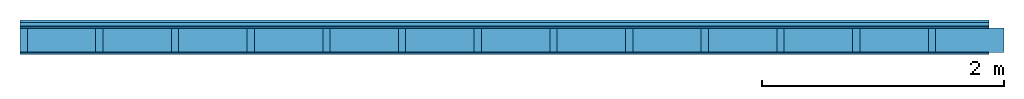
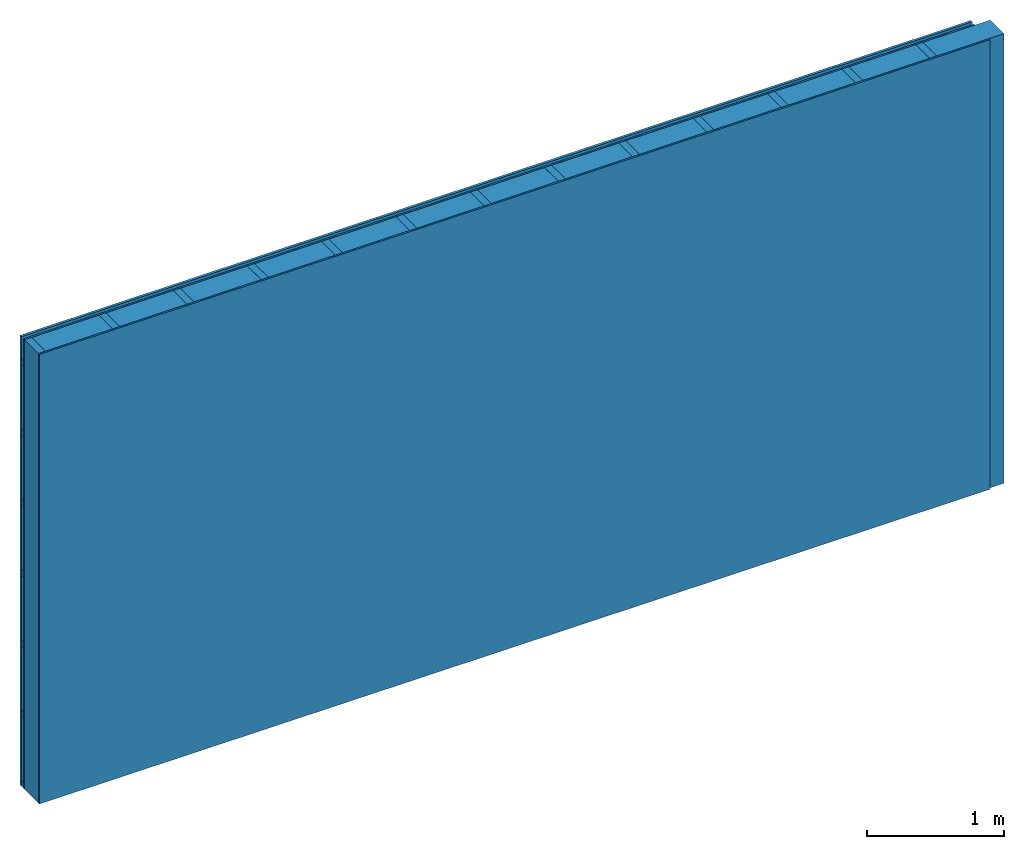
# One storey: 3 members, 3 plates, 1 element without a shape of its own.
"""IFC4 building model written with IfcOpenShell, lengths in metres."""

from ifc_helpers import new_model, si_unit, derived_unit, direction, frame, frame_2d, origin, origin_with_axes, place, context, project, spatial, rectangle, extrude, material, layer, layer_set, type_object, element, aggregate, save


model = new_model("IFC4")

# Units and contexts
plan_context = context("Plan", 3, precision=1e-05, world=origin(), true_north=direction((0.0, 1.0)))
model_context = context("Model", 3, precision=1e-05, world=origin(), true_north=direction((0.0, 1.0)))
ifc_project = project(units=[si_unit("LENGTHUNIT", "METRE"), derived_unit("SOUNDPRESSUREUNIT", [(si_unit("PRESSUREUNIT", "PASCAL", prefix="MICRO"), 0)]), si_unit("ENERGYUNIT", "JOULE", prefix="MEGA"), si_unit("MASSUNIT", "GRAM", prefix="KILO"), derived_unit("THERMALTRANSMITTANCEUNIT", [(si_unit("POWERUNIT", "WATT"), 1), (si_unit("AREAUNIT", "SQUARE_METRE"), -1), (si_unit("THERMODYNAMICTEMPERATUREUNIT", "KELVIN"), -1)]), derived_unit("AREADENSITYUNIT", [(si_unit("MASSUNIT", "GRAM", prefix="KILO"), 1), (si_unit("AREAUNIT", "SQUARE_METRE"), -1)]), derived_unit("USERDEFINED", [(si_unit("ENERGYUNIT", "JOULE", prefix="MEGA"), 1), (si_unit("AREAUNIT", "SQUARE_METRE"), -1)])], contexts=[plan_context, model_context])

# Site, building, storey
site = spatial("IfcSite", under=ifc_project)
building_placement = place(None, origin())
building = spatial("IfcBuilding", under=site, at=building_placement)
storey_placement = place(building_placement, origin())
storey = spatial("IfcBuildingStorey", under=building, at=storey_placement)

# Wall, members, plates
ifc_material_1 = material(Name="Wood cladding horizontal, closed")
ifc_layer_1 = layer(ifc_material_1, 0.022, Name="Cover 1st layer")
ifc_layer_2 = layer(None, 0.03, Name="Battens / profiles (ventilation)")
ifc_material_2 = material(Category="07.013")
ifc_layer_3 = layer(ifc_material_2, 0.015, Name="outside 1st layer")
ifc_material_3 = material(Name="of the art")
ifc_layer_4 = layer(ifc_material_3, 0.0, Name="Bond")
ifc_layer_5 = layer(None, 0.2, Name="Support")
ifc_layer_6 = layer(ifc_material_3, 0.0, Name="Bond")
ifc_material_4 = material(Category="03.007")
ifc_layer_7 = layer(ifc_material_4, 0.015, Name="1st layer")
ifc_material_5 = material(Name="Glued joints")
ifc_layer_8 = layer(ifc_material_5, 0.0, Name="Surface")
ifc_layer_set = layer_set([ifc_layer_1, ifc_layer_2, ifc_layer_3, ifc_layer_4, ifc_layer_5, ifc_layer_6, ifc_layer_7, ifc_layer_8])
wall_type = type_object("IfcWallType", Name="D0085", PredefinedType="NOTDEFINED", material=ifc_layer_set)
wall_placement = place(None, frame((0.0, 0.0, 0.0), z_axis=(0.0, -1.0, 0.0), x_axis=(1.0, 0.0, 0.0)))
wall = element("IfcWall", 1, at=wall_placement, inside=storey, type_object=wall_type, material=ifc_layer_set, Name="Wall #1")
ifc_material_6 = material()
member_1_placement = place(wall_placement, origin())
member_1 = element("IfcMember", 2, at=member_1_placement, material=ifc_material_6, Name="Battens / profiles (ventilation)", context=plan_context, shape_type="SweptSolid", body=[
    extrude(rectangle(XDim=0.05, YDim=0.03, at=frame_2d((0.025, 0.015), x_axis=(1.0, 0.0))), frame((0.0, 0.0, 0.022), z_axis=(1.0, 0.0, 0.0), x_axis=(0.0, 1.0, 0.0)), (0.0, 0.0, 1.0), 8.0),
    extrude(rectangle(XDim=0.05, YDim=0.03, at=frame_2d((0.025, 0.015), x_axis=(1.0, 0.0))), frame((0.0, 0.625, 0.022), z_axis=(1.0, 0.0, 0.0), x_axis=(0.0, 1.0, 0.0)), (0.0, 0.0, 1.0), 8.0),
    extrude(rectangle(XDim=0.05, YDim=0.03, at=frame_2d((0.025, 0.015), x_axis=(1.0, 0.0))), frame((0.0, 1.25, 0.022), z_axis=(1.0, 0.0, 0.0), x_axis=(0.0, 1.0, 0.0)), (0.0, 0.0, 1.0), 8.0),
    extrude(rectangle(XDim=0.05, YDim=0.03, at=frame_2d((0.025, 0.015), x_axis=(1.0, 0.0))), frame((0.0, 1.875, 0.022), z_axis=(1.0, 0.0, 0.0), x_axis=(0.0, 1.0, 0.0)), (0.0, 0.0, 1.0), 8.0),
    extrude(rectangle(XDim=0.05, YDim=0.03, at=frame_2d((0.025, 0.015), x_axis=(1.0, 0.0))), frame((0.0, 2.5, 0.022), z_axis=(1.0, 0.0, 0.0), x_axis=(0.0, 1.0, 0.0)), (0.0, 0.0, 1.0), 8.0),
    extrude(rectangle(XDim=0.05, YDim=0.03, at=frame_2d((0.025, 0.015), x_axis=(1.0, 0.0))), frame((0.0, 3.125, 0.022), z_axis=(1.0, 0.0, 0.0), x_axis=(0.0, 1.0, 0.0)), (0.0, 0.0, 1.0), 8.0),
    extrude(rectangle(XDim=0.05, YDim=0.03, at=frame_2d((0.025, 0.015), x_axis=(1.0, 0.0))), frame((0.0, 3.75, 0.022), z_axis=(1.0, 0.0, 0.0), x_axis=(0.0, 1.0, 0.0)), (0.0, 0.0, 1.0), 8.0),
])
ifc_material_7 = material()
member_2_placement = place(wall_placement, origin())
member_2 = element("IfcMember", 3, at=member_2_placement, material=ifc_material_7, Name="Support", context=plan_context, shape_type="SweptSolid", body=[
    extrude(rectangle(XDim=0.06, YDim=0.2, at=frame_2d((0.03, 0.1), x_axis=(1.0, 0.0))), frame((0.0, 4.0, 0.067), z_axis=(0.0, -1.0, 0.0), x_axis=(1.0, 0.0, 0.0)), (0.0, 0.0, 1.0), 4.0),
    extrude(rectangle(XDim=0.06, YDim=0.2, at=frame_2d((0.03, 0.1), x_axis=(1.0, 0.0))), frame((0.625, 4.0, 0.067), z_axis=(0.0, -1.0, 0.0), x_axis=(1.0, 0.0, 0.0)), (0.0, 0.0, 1.0), 4.0),
    extrude(rectangle(XDim=0.06, YDim=0.2, at=frame_2d((0.03, 0.1), x_axis=(1.0, 0.0))), frame((1.25, 4.0, 0.067), z_axis=(0.0, -1.0, 0.0), x_axis=(1.0, 0.0, 0.0)), (0.0, 0.0, 1.0), 4.0),
    extrude(rectangle(XDim=0.06, YDim=0.2, at=frame_2d((0.03, 0.1), x_axis=(1.0, 0.0))), frame((1.875, 4.0, 0.067), z_axis=(0.0, -1.0, 0.0), x_axis=(1.0, 0.0, 0.0)), (0.0, 0.0, 1.0), 4.0),
    extrude(rectangle(XDim=0.06, YDim=0.2, at=frame_2d((0.03, 0.1), x_axis=(1.0, 0.0))), frame((2.5, 4.0, 0.067), z_axis=(0.0, -1.0, 0.0), x_axis=(1.0, 0.0, 0.0)), (0.0, 0.0, 1.0), 4.0),
    extrude(rectangle(XDim=0.06, YDim=0.2, at=frame_2d((0.03, 0.1), x_axis=(1.0, 0.0))), frame((3.125, 4.0, 0.067), z_axis=(0.0, -1.0, 0.0), x_axis=(1.0, 0.0, 0.0)), (0.0, 0.0, 1.0), 4.0),
    extrude(rectangle(XDim=0.06, YDim=0.2, at=frame_2d((0.03, 0.1), x_axis=(1.0, 0.0))), frame((3.75, 4.0, 0.067), z_axis=(0.0, -1.0, 0.0), x_axis=(1.0, 0.0, 0.0)), (0.0, 0.0, 1.0), 4.0),
    extrude(rectangle(XDim=0.06, YDim=0.2, at=frame_2d((0.03, 0.1), x_axis=(1.0, 0.0))), frame((4.375, 4.0, 0.067), z_axis=(0.0, -1.0, 0.0), x_axis=(1.0, 0.0, 0.0)), (0.0, 0.0, 1.0), 4.0),
    extrude(rectangle(XDim=0.06, YDim=0.2, at=frame_2d((0.03, 0.1), x_axis=(1.0, 0.0))), frame((5.0, 4.0, 0.067), z_axis=(0.0, -1.0, 0.0), x_axis=(1.0, 0.0, 0.0)), (0.0, 0.0, 1.0), 4.0),
    extrude(rectangle(XDim=0.06, YDim=0.2, at=frame_2d((0.03, 0.1), x_axis=(1.0, 0.0))), frame((5.625, 4.0, 0.067), z_axis=(0.0, -1.0, 0.0), x_axis=(1.0, 0.0, 0.0)), (0.0, 0.0, 1.0), 4.0),
    extrude(rectangle(XDim=0.06, YDim=0.2, at=frame_2d((0.03, 0.1), x_axis=(1.0, 0.0))), frame((6.25, 4.0, 0.067), z_axis=(0.0, -1.0, 0.0), x_axis=(1.0, 0.0, 0.0)), (0.0, 0.0, 1.0), 4.0),
    extrude(rectangle(XDim=0.06, YDim=0.2, at=frame_2d((0.03, 0.1), x_axis=(1.0, 0.0))), frame((6.875, 4.0, 0.067), z_axis=(0.0, -1.0, 0.0), x_axis=(1.0, 0.0, 0.0)), (0.0, 0.0, 1.0), 4.0),
    extrude(rectangle(XDim=0.06, YDim=0.2, at=frame_2d((0.03, 0.1), x_axis=(1.0, 0.0))), frame((7.5, 4.0, 0.067), z_axis=(0.0, -1.0, 0.0), x_axis=(1.0, 0.0, 0.0)), (0.0, 0.0, 1.0), 4.0),
])
ifc_material_8 = material()
member_3_placement = place(wall_placement, origin())
member_3 = element("IfcMember", 4, at=member_3_placement, material=ifc_material_8, Name="Cavity", context=plan_context, shape_type="SweptSolid", body=[
    extrude(rectangle(XDim=0.565, YDim=0.2, at=frame_2d((0.2825, 0.1), x_axis=(1.0, 0.0))), frame((0.06, 4.0, 0.067), z_axis=(0.0, -1.0, 0.0), x_axis=(1.0, 0.0, 0.0)), (0.0, 0.0, 1.0), 4.0),
    extrude(rectangle(XDim=0.565, YDim=0.2, at=frame_2d((0.2825, 0.1), x_axis=(1.0, 0.0))), frame((0.685, 4.0, 0.067), z_axis=(0.0, -1.0, 0.0), x_axis=(1.0, 0.0, 0.0)), (0.0, 0.0, 1.0), 4.0),
    extrude(rectangle(XDim=0.565, YDim=0.2, at=frame_2d((0.2825, 0.1), x_axis=(1.0, 0.0))), frame((1.31, 4.0, 0.067), z_axis=(0.0, -1.0, 0.0), x_axis=(1.0, 0.0, 0.0)), (0.0, 0.0, 1.0), 4.0),
    extrude(rectangle(XDim=0.565, YDim=0.2, at=frame_2d((0.2825, 0.1), x_axis=(1.0, 0.0))), frame((1.935, 4.0, 0.067), z_axis=(0.0, -1.0, 0.0), x_axis=(1.0, 0.0, 0.0)), (0.0, 0.0, 1.0), 4.0),
    extrude(rectangle(XDim=0.565, YDim=0.2, at=frame_2d((0.2825, 0.1), x_axis=(1.0, 0.0))), frame((2.56, 4.0, 0.067), z_axis=(0.0, -1.0, 0.0), x_axis=(1.0, 0.0, 0.0)), (0.0, 0.0, 1.0), 4.0),
    extrude(rectangle(XDim=0.565, YDim=0.2, at=frame_2d((0.2825, 0.1), x_axis=(1.0, 0.0))), frame((3.185, 4.0, 0.067), z_axis=(0.0, -1.0, 0.0), x_axis=(1.0, 0.0, 0.0)), (0.0, 0.0, 1.0), 4.0),
    extrude(rectangle(XDim=0.565, YDim=0.2, at=frame_2d((0.2825, 0.1), x_axis=(1.0, 0.0))), frame((3.81, 4.0, 0.067), z_axis=(0.0, -1.0, 0.0), x_axis=(1.0, 0.0, 0.0)), (0.0, 0.0, 1.0), 4.0),
    extrude(rectangle(XDim=0.565, YDim=0.2, at=frame_2d((0.2825, 0.1), x_axis=(1.0, 0.0))), frame((4.435, 4.0, 0.067), z_axis=(0.0, -1.0, 0.0), x_axis=(1.0, 0.0, 0.0)), (0.0, 0.0, 1.0), 4.0),
    extrude(rectangle(XDim=0.565, YDim=0.2, at=frame_2d((0.2825, 0.1), x_axis=(1.0, 0.0))), frame((5.06, 4.0, 0.067), z_axis=(0.0, -1.0, 0.0), x_axis=(1.0, 0.0, 0.0)), (0.0, 0.0, 1.0), 4.0),
    extrude(rectangle(XDim=0.565, YDim=0.2, at=frame_2d((0.2825, 0.1), x_axis=(1.0, 0.0))), frame((5.685, 4.0, 0.067), z_axis=(0.0, -1.0, 0.0), x_axis=(1.0, 0.0, 0.0)), (0.0, 0.0, 1.0), 4.0),
    extrude(rectangle(XDim=0.565, YDim=0.2, at=frame_2d((0.2825, 0.1), x_axis=(1.0, 0.0))), frame((6.31, 4.0, 0.067), z_axis=(0.0, -1.0, 0.0), x_axis=(1.0, 0.0, 0.0)), (0.0, 0.0, 1.0), 4.0),
    extrude(rectangle(XDim=0.565, YDim=0.2, at=frame_2d((0.2825, 0.1), x_axis=(1.0, 0.0))), frame((6.935, 4.0, 0.067), z_axis=(0.0, -1.0, 0.0), x_axis=(1.0, 0.0, 0.0)), (0.0, 0.0, 1.0), 4.0),
    extrude(rectangle(XDim=0.565, YDim=0.2, at=frame_2d((0.2825, 0.1), x_axis=(1.0, 0.0))), frame((7.56, 4.0, 0.067), z_axis=(0.0, -1.0, 0.0), x_axis=(1.0, 0.0, 0.0)), (0.0, 0.0, 1.0), 4.0),
])
plate_1_placement = place(wall_placement, origin())
plate_1 = element("IfcPlate", 5, at=plate_1_placement, material=ifc_material_1, Name="Cover 1st layer", context=plan_context, shape_type="SweptSolid", body=[
    extrude(rectangle(XDim=8.0, YDim=4.0, at=frame_2d((4.0, 2.0), x_axis=(1.0, 0.0))), origin_with_axes(), (0.0, 0.0, 1.0), 0.022),
])
plate_2_placement = place(wall_placement, origin())
plate_2 = element("IfcPlate", 6, at=plate_2_placement, material=ifc_material_2, Name="outside 1st layer", context=plan_context, shape_type="SweptSolid", body=[
    extrude(rectangle(XDim=8.0, YDim=4.0, at=frame_2d((4.0, 2.0), x_axis=(1.0, 0.0))), frame((0.0, 0.0, 0.052), z_axis=(0.0, 0.0, 1.0), x_axis=(1.0, 0.0, 0.0)), (0.0, 0.0, 1.0), 0.015),
])
plate_3_placement = place(wall_placement, origin())
plate_3 = element("IfcPlate", 7, at=plate_3_placement, material=ifc_material_4, Name="1st layer", context=plan_context, shape_type="SweptSolid", body=[
    extrude(rectangle(XDim=8.0, YDim=4.0, at=frame_2d((4.0, 2.0), x_axis=(1.0, 0.0))), frame((0.0, 0.0, 0.267), z_axis=(0.0, 0.0, 1.0), x_axis=(1.0, 0.0, 0.0)), (0.0, 0.0, 1.0), 0.015),
])
aggregate(wall, [plate_1, member_1, plate_2, member_2, member_3, plate_3])

save(model, "model.ifc")
